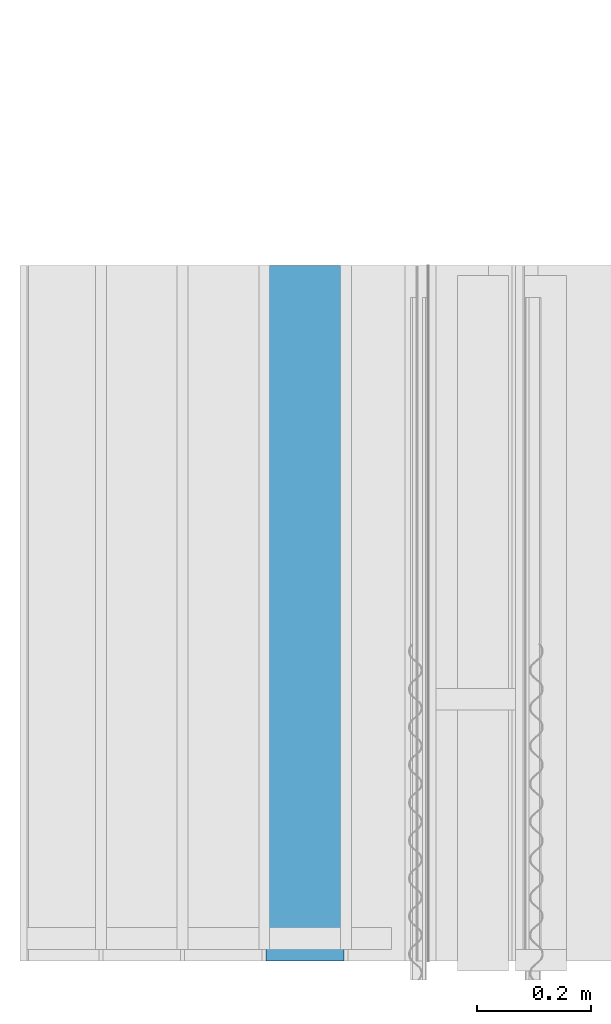
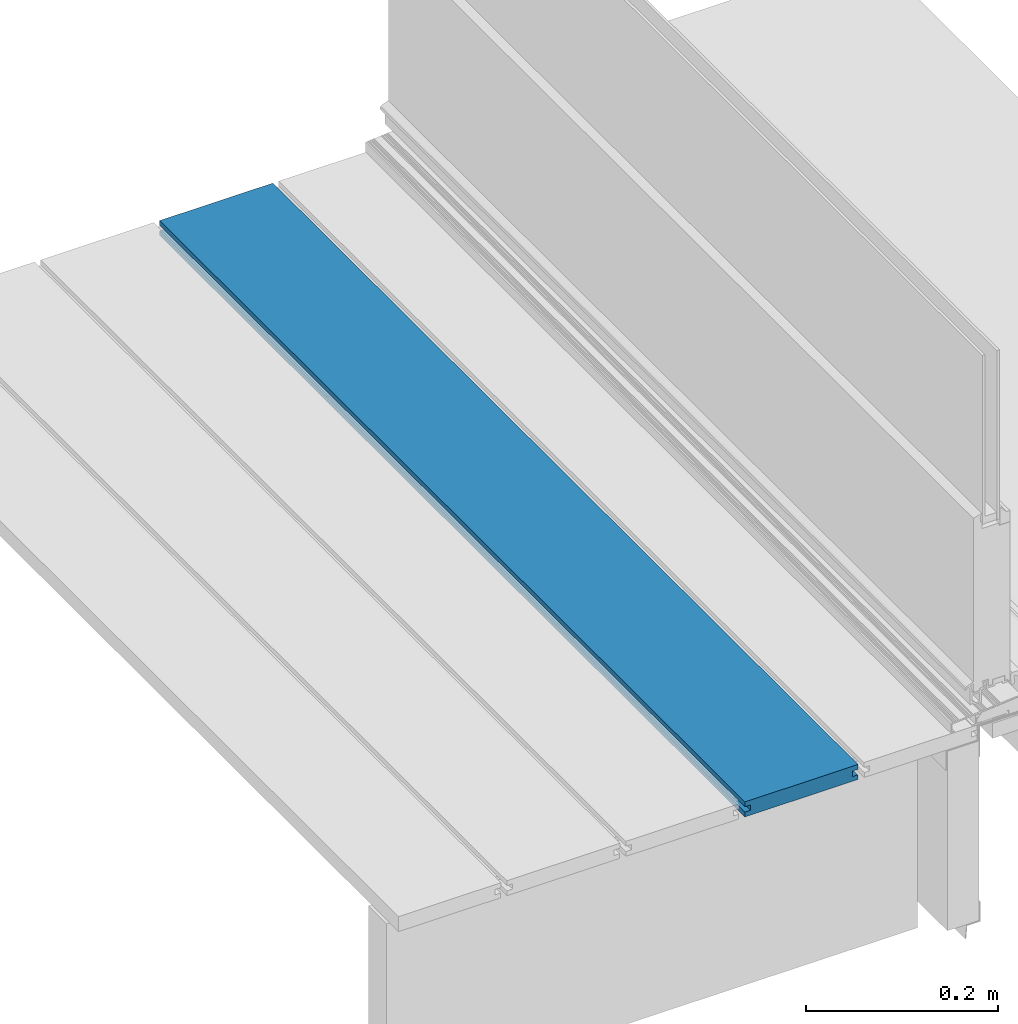
# One storey, part 5 of 33: 1 wall.
"""IFC4 building model written with IfcOpenShell, lengths in feet."""

from ifc_helpers import new_model, entity, si_unit, converted_unit, derived_unit, direction, frame, origin, place, context, subcontext, project, spatial, material, type_object, element, save


model = new_model("IFC4")

# Units and contexts
model_context = context("Model", 3, precision=0.0001, world=origin(), true_north=direction((6.12303176911189e-17, 1.0)))
body_context = subcontext(model_context, "Body", "Model", "MODEL_VIEW")
ifc_project = project(units=[converted_unit("LENGTHUNIT", "FOOT", entity("IfcRatioMeasure", 0.3048), si_unit("LENGTHUNIT", "METRE"), dimensions=[1, 0, 0, 0, 0, 0, 0]), converted_unit("AREAUNIT", "SQUARE FOOT", entity("IfcRatioMeasure", 0.09290304), si_unit("AREAUNIT", "SQUARE_METRE"), dimensions=[2, 0, 0, 0, 0, 0, 0]), converted_unit("VOLUMEUNIT", "CUBIC FOOT", entity("IfcRatioMeasure", 0.028316846592), si_unit("VOLUMEUNIT", "CUBIC_METRE"), dimensions=[3, 0, 0, 0, 0, 0, 0]), converted_unit("PLANEANGLEUNIT", "DEGREE", entity("IfcRatioMeasure", 0.0174532925199433), si_unit("PLANEANGLEUNIT", "RADIAN"), dimensions=[0, 0, 0, 0, 0, 0, 0]), si_unit("MASSUNIT", "GRAM", prefix="KILO"), derived_unit("MASSDENSITYUNIT", [(si_unit("MASSUNIT", "GRAM", prefix="KILO"), 1), (si_unit("LENGTHUNIT", "METRE"), -3)]), derived_unit("MOMENTOFINERTIAUNIT", [(si_unit("LENGTHUNIT", "METRE"), 4)]), si_unit("TIMEUNIT", "SECOND"), si_unit("FREQUENCYUNIT", "HERTZ"), si_unit("THERMODYNAMICTEMPERATUREUNIT", "DEGREE_CELSIUS"), derived_unit("THERMALTRANSMITTANCEUNIT", [(si_unit("MASSUNIT", "GRAM", prefix="KILO"), 1), (si_unit("THERMODYNAMICTEMPERATUREUNIT", "KELVIN"), -1), (si_unit("TIMEUNIT", "SECOND"), -3)]), derived_unit("VOLUMETRICFLOWRATEUNIT", [(si_unit("LENGTHUNIT", "METRE"), 3), (si_unit("TIMEUNIT", "SECOND"), -1)]), si_unit("ELECTRICCURRENTUNIT", "AMPERE"), si_unit("ELECTRICVOLTAGEUNIT", "VOLT"), si_unit("POWERUNIT", "WATT"), si_unit("FORCEUNIT", "NEWTON"), si_unit("ILLUMINANCEUNIT", "LUX"), si_unit("LUMINOUSFLUXUNIT", "LUMEN"), si_unit("LUMINOUSINTENSITYUNIT", "CANDELA"), derived_unit("USERDEFINED", [(si_unit("MASSUNIT", "GRAM", prefix="KILO"), -1), (si_unit("LENGTHUNIT", "METRE"), -2), (si_unit("TIMEUNIT", "SECOND"), 3), (si_unit("LUMINOUSFLUXUNIT", "LUMEN"), 1)]), derived_unit("LINEARVELOCITYUNIT", [(si_unit("LENGTHUNIT", "METRE"), 1), (si_unit("TIMEUNIT", "SECOND"), -1)]), si_unit("PRESSUREUNIT", "PASCAL"), derived_unit("USERDEFINED", [(si_unit("LENGTHUNIT", "METRE"), -2), (si_unit("MASSUNIT", "GRAM", prefix="KILO"), 1), (si_unit("TIMEUNIT", "SECOND"), -2)]), derived_unit("LINEARFORCEUNIT", [(si_unit("MASSUNIT", "GRAM", prefix="KILO"), 1), (si_unit("LENGTHUNIT", "METRE"), 1), (si_unit("TIMEUNIT", "SECOND"), -2), (si_unit("LENGTHUNIT", "METRE"), -1)]), derived_unit("PLANARFORCEUNIT", [(si_unit("MASSUNIT", "GRAM", prefix="KILO"), 1), (si_unit("LENGTHUNIT", "METRE"), 1), (si_unit("TIMEUNIT", "SECOND"), -2), (si_unit("LENGTHUNIT", "METRE"), -2)])], contexts=[model_context])

# Site, building, storey
site_placement = place(None, origin())
site = spatial("IfcSite", under=ifc_project, at=site_placement, CompositionType="ELEMENT")
building_placement = place(site_placement, origin())
building = spatial("IfcBuilding", under=site, at=building_placement, CompositionType="ELEMENT")
storey_placement = place(building_placement, frame((0.0, 0.0, 10.0)))
storey = spatial("IfcBuildingStorey", under=building, at=storey_placement, Name="2ND FLOOR", CompositionType="ELEMENT", Elevation=10.0000000000002)

# Wall
ifc_material = material(Name="COMPOSITE DECKING W/ HIDDEN FASTENERS", Category="Materials")
wall_type = type_object("IfcWallType", Name="Generic Models 641:Generic Models 1", PredefinedType="NOTDEFINED", material=ifc_material)
wall_placement = place(storey_placement, frame((1458.33405136118, 2.0, 0.618921366607442), z_axis=(0.0, 0.0, 1.0), x_axis=(0.0, 1.0, 0.0)))
cartesian_point_1 = entity("IfcCartesianPoint", [4.0, 0.0, 0.0])
vertex_point_1 = entity("IfcVertexPoint", cartesian_point_1)
cartesian_point_2 = entity("IfcCartesianPoint", [4.0, 0.0, 0.0198779960861497])
vertex_point_2 = entity("IfcVertexPoint", cartesian_point_2)
ifc_direction_1 = entity("IfcDirection", [0.0, 0.0, 1.0])
edge_curve_1 = entity("IfcEdgeCurve", vertex_point_1, vertex_point_2, entity("IfcTrimmedCurve", entity("IfcLine", cartesian_point_1, entity("IfcVector", ifc_direction_1, 1.0)), [cartesian_point_1], [cartesian_point_2], True, "CARTESIAN"), True)
cartesian_point_3 = entity("IfcCartesianPoint", [4.0, -0.0228400010810219, 0.0198779960861497])
vertex_point_3 = entity("IfcVertexPoint", cartesian_point_3)
ifc_direction_2 = entity("IfcDirection", [0.0, -1.0, 0.0])
edge_curve_2 = entity("IfcEdgeCurve", vertex_point_2, vertex_point_3, entity("IfcTrimmedCurve", entity("IfcLine", cartesian_point_2, entity("IfcVector", ifc_direction_2, 1.0)), [cartesian_point_2], [cartesian_point_3], True, "CARTESIAN"), True)
cartesian_point_4 = entity("IfcCartesianPoint", [4.0, -0.0228400010810219, 0.0422987663426539])
vertex_point_4 = entity("IfcVertexPoint", cartesian_point_4)
edge_curve_3 = entity("IfcEdgeCurve", vertex_point_3, vertex_point_4, entity("IfcTrimmedCurve", entity("IfcLine", cartesian_point_3, entity("IfcVector", ifc_direction_1, 1.0)), [cartesian_point_3], [cartesian_point_4], True, "CARTESIAN"), True)
cartesian_point_5 = entity("IfcCartesianPoint", [4.0, 0.0, 0.0422987663426539])
vertex_point_5 = entity("IfcVertexPoint", cartesian_point_5)
ifc_direction_3 = entity("IfcDirection", [0.0, 1.0, 0.0])
edge_curve_4 = entity("IfcEdgeCurve", vertex_point_4, vertex_point_5, entity("IfcTrimmedCurve", entity("IfcLine", cartesian_point_4, entity("IfcVector", ifc_direction_3, 1.0)), [cartesian_point_4], [cartesian_point_5], True, "CARTESIAN"), True)
cartesian_point_6 = entity("IfcCartesianPoint", [4.0, 0.0, 0.0625000000000018])
vertex_point_6 = entity("IfcVertexPoint", cartesian_point_6)
edge_curve_5 = entity("IfcEdgeCurve", vertex_point_5, vertex_point_6, entity("IfcTrimmedCurve", entity("IfcLine", cartesian_point_5, entity("IfcVector", ifc_direction_1, 1.0)), [cartesian_point_5], [cartesian_point_6], True, "CARTESIAN"), True)
cartesian_point_7 = entity("IfcCartesianPoint", [4.0, -0.446740923891639, 0.0625000000000568])
vertex_point_7 = entity("IfcVertexPoint", cartesian_point_7)
edge_curve_6 = entity("IfcEdgeCurve", vertex_point_6, vertex_point_7, entity("IfcTrimmedCurve", entity("IfcLine", cartesian_point_6, entity("IfcVector", ifc_direction_2, 1.0)), [cartesian_point_6], [cartesian_point_7], True, "CARTESIAN"), True)
cartesian_point_8 = entity("IfcCartesianPoint", [4.0, -0.446740923891639, 0.0422987663426539])
vertex_point_8 = entity("IfcVertexPoint", cartesian_point_8)
ifc_direction_4 = entity("IfcDirection", [0.0, 0.0, -1.0])
edge_curve_7 = entity("IfcEdgeCurve", vertex_point_7, vertex_point_8, entity("IfcTrimmedCurve", entity("IfcLine", cartesian_point_7, entity("IfcVector", ifc_direction_4, 1.0)), [cartesian_point_7], [cartesian_point_8], True, "CARTESIAN"), True)
cartesian_point_9 = entity("IfcCartesianPoint", [4.0, -0.423900922810844, 0.0422987663426539])
vertex_point_9 = entity("IfcVertexPoint", cartesian_point_9)
edge_curve_8 = entity("IfcEdgeCurve", vertex_point_8, vertex_point_9, entity("IfcTrimmedCurve", entity("IfcLine", cartesian_point_8, entity("IfcVector", ifc_direction_3, 1.0)), [cartesian_point_8], [cartesian_point_9], True, "CARTESIAN"), True)
cartesian_point_10 = entity("IfcCartesianPoint", [4.0, -0.423900922810844, 0.0198779960861497])
vertex_point_10 = entity("IfcVertexPoint", cartesian_point_10)
edge_curve_9 = entity("IfcEdgeCurve", vertex_point_9, vertex_point_10, entity("IfcTrimmedCurve", entity("IfcLine", cartesian_point_9, entity("IfcVector", ifc_direction_4, 1.0)), [cartesian_point_9], [cartesian_point_10], True, "CARTESIAN"), True)
cartesian_point_11 = entity("IfcCartesianPoint", [4.0, -0.445416170097133, 0.0198779960861497])
vertex_point_11 = entity("IfcVertexPoint", cartesian_point_11)
edge_curve_10 = entity("IfcEdgeCurve", vertex_point_10, vertex_point_11, entity("IfcTrimmedCurve", entity("IfcLine", cartesian_point_10, entity("IfcVector", ifc_direction_2, 1.0)), [cartesian_point_10], [cartesian_point_11], True, "CARTESIAN"), True)
cartesian_point_12 = entity("IfcCartesianPoint", [4.0, -0.445416170097133, 0.0])
vertex_point_12 = entity("IfcVertexPoint", cartesian_point_12)
edge_curve_11 = entity("IfcEdgeCurve", vertex_point_11, vertex_point_12, entity("IfcTrimmedCurve", entity("IfcLine", cartesian_point_11, entity("IfcVector", ifc_direction_4, 1.0)), [cartesian_point_11], [cartesian_point_12], True, "CARTESIAN"), True)
edge_curve_12 = entity("IfcEdgeCurve", vertex_point_12, vertex_point_1, entity("IfcTrimmedCurve", entity("IfcLine", cartesian_point_12, entity("IfcVector", ifc_direction_3, 1.0)), [cartesian_point_12], [cartesian_point_1], True, "CARTESIAN"), True)
ifc_direction_5 = entity("IfcDirection", [1.0, 0.0, 0.0])
cartesian_point_13 = entity("IfcCartesianPoint", [0.0, 0.0, 0.0])
vertex_point_13 = entity("IfcVertexPoint", cartesian_point_13)
cartesian_point_14 = entity("IfcCartesianPoint", [0.0, -0.445416170097133, 0.0])
vertex_point_14 = entity("IfcVertexPoint", cartesian_point_14)
edge_curve_13 = entity("IfcEdgeCurve", vertex_point_13, vertex_point_14, entity("IfcTrimmedCurve", entity("IfcLine", cartesian_point_13, entity("IfcVector", ifc_direction_2, 1.0)), [cartesian_point_13], [cartesian_point_14], True, "CARTESIAN"), True)
cartesian_point_15 = entity("IfcCartesianPoint", [0.0, -0.445416170097133, 0.0198779960861462])
vertex_point_15 = entity("IfcVertexPoint", cartesian_point_15)
edge_curve_14 = entity("IfcEdgeCurve", vertex_point_14, vertex_point_15, entity("IfcTrimmedCurve", entity("IfcLine", cartesian_point_14, entity("IfcVector", ifc_direction_1, 1.0)), [cartesian_point_14], [cartesian_point_15], True, "CARTESIAN"), True)
cartesian_point_16 = entity("IfcCartesianPoint", [0.0, -0.423900922810844, 0.0198779960861462])
vertex_point_16 = entity("IfcVertexPoint", cartesian_point_16)
edge_curve_15 = entity("IfcEdgeCurve", vertex_point_15, vertex_point_16, entity("IfcTrimmedCurve", entity("IfcLine", cartesian_point_15, entity("IfcVector", ifc_direction_3, 1.0)), [cartesian_point_15], [cartesian_point_16], True, "CARTESIAN"), True)
cartesian_point_17 = entity("IfcCartesianPoint", [0.0, -0.423900922810844, 0.0422987663426522])
vertex_point_17 = entity("IfcVertexPoint", cartesian_point_17)
edge_curve_16 = entity("IfcEdgeCurve", vertex_point_16, vertex_point_17, entity("IfcTrimmedCurve", entity("IfcLine", cartesian_point_16, entity("IfcVector", ifc_direction_1, 1.0)), [cartesian_point_16], [cartesian_point_17], True, "CARTESIAN"), True)
cartesian_point_18 = entity("IfcCartesianPoint", [0.0, -0.446740923891639, 0.0422987663426522])
vertex_point_18 = entity("IfcVertexPoint", cartesian_point_18)
edge_curve_17 = entity("IfcEdgeCurve", vertex_point_17, vertex_point_18, entity("IfcTrimmedCurve", entity("IfcLine", cartesian_point_17, entity("IfcVector", ifc_direction_2, 1.0)), [cartesian_point_17], [cartesian_point_18], True, "CARTESIAN"), True)
cartesian_point_19 = entity("IfcCartesianPoint", [0.0, -0.446740923891639, 0.0625000000000551])
vertex_point_19 = entity("IfcVertexPoint", cartesian_point_19)
edge_curve_18 = entity("IfcEdgeCurve", vertex_point_18, vertex_point_19, entity("IfcTrimmedCurve", entity("IfcLine", cartesian_point_18, entity("IfcVector", ifc_direction_1, 1.0)), [cartesian_point_18], [cartesian_point_19], True, "CARTESIAN"), True)
cartesian_point_20 = entity("IfcCartesianPoint", [0.0, 0.0, 0.0624999999999982])
vertex_point_20 = entity("IfcVertexPoint", cartesian_point_20)
edge_curve_19 = entity("IfcEdgeCurve", vertex_point_19, vertex_point_20, entity("IfcTrimmedCurve", entity("IfcLine", cartesian_point_19, entity("IfcVector", ifc_direction_3, 1.0)), [cartesian_point_19], [cartesian_point_20], True, "CARTESIAN"), True)
cartesian_point_21 = entity("IfcCartesianPoint", [0.0, 0.0, 0.0422987663426522])
vertex_point_21 = entity("IfcVertexPoint", cartesian_point_21)
edge_curve_20 = entity("IfcEdgeCurve", vertex_point_20, vertex_point_21, entity("IfcTrimmedCurve", entity("IfcLine", cartesian_point_20, entity("IfcVector", ifc_direction_4, 1.0)), [cartesian_point_20], [cartesian_point_21], True, "CARTESIAN"), True)
cartesian_point_22 = entity("IfcCartesianPoint", [0.0, -0.0228400010810219, 0.0422987663426522])
vertex_point_22 = entity("IfcVertexPoint", cartesian_point_22)
edge_curve_21 = entity("IfcEdgeCurve", vertex_point_21, vertex_point_22, entity("IfcTrimmedCurve", entity("IfcLine", cartesian_point_21, entity("IfcVector", ifc_direction_2, 1.0)), [cartesian_point_21], [cartesian_point_22], True, "CARTESIAN"), True)
cartesian_point_23 = entity("IfcCartesianPoint", [0.0, -0.0228400010810219, 0.0198779960861462])
vertex_point_23 = entity("IfcVertexPoint", cartesian_point_23)
edge_curve_22 = entity("IfcEdgeCurve", vertex_point_22, vertex_point_23, entity("IfcTrimmedCurve", entity("IfcLine", cartesian_point_22, entity("IfcVector", ifc_direction_4, 1.0)), [cartesian_point_22], [cartesian_point_23], True, "CARTESIAN"), True)
cartesian_point_24 = entity("IfcCartesianPoint", [0.0, 0.0, 0.0198779960861462])
vertex_point_24 = entity("IfcVertexPoint", cartesian_point_24)
edge_curve_23 = entity("IfcEdgeCurve", vertex_point_23, vertex_point_24, entity("IfcTrimmedCurve", entity("IfcLine", cartesian_point_23, entity("IfcVector", ifc_direction_3, 1.0)), [cartesian_point_23], [cartesian_point_24], True, "CARTESIAN"), True)
edge_curve_24 = entity("IfcEdgeCurve", vertex_point_24, vertex_point_13, entity("IfcTrimmedCurve", entity("IfcLine", cartesian_point_24, entity("IfcVector", ifc_direction_4, 1.0)), [cartesian_point_24], [cartesian_point_13], True, "CARTESIAN"), True)
ifc_direction_6 = entity("IfcDirection", [-1.0, 0.0, 0.0])
edge_curve_25 = entity("IfcEdgeCurve", vertex_point_24, vertex_point_2, entity("IfcTrimmedCurve", entity("IfcLine", cartesian_point_24, entity("IfcVector", ifc_direction_5, 1.0)), [cartesian_point_24], [cartesian_point_2], True, "CARTESIAN"), True)
edge_curve_26 = entity("IfcEdgeCurve", vertex_point_1, vertex_point_13, entity("IfcTrimmedCurve", entity("IfcLine", cartesian_point_13, entity("IfcVector", ifc_direction_6, 1.0)), [cartesian_point_1], [cartesian_point_13], True, "CARTESIAN"), True)
edge_curve_27 = entity("IfcEdgeCurve", vertex_point_19, vertex_point_7, entity("IfcTrimmedCurve", entity("IfcLine", cartesian_point_19, entity("IfcVector", ifc_direction_5, 1.0)), [cartesian_point_19], [cartesian_point_7], True, "CARTESIAN"), True)
edge_curve_28 = entity("IfcEdgeCurve", vertex_point_6, vertex_point_20, entity("IfcTrimmedCurve", entity("IfcLine", cartesian_point_20, entity("IfcVector", ifc_direction_6, 1.0)), [cartesian_point_6], [cartesian_point_20], True, "CARTESIAN"), True)
edge_curve_29 = entity("IfcEdgeCurve", vertex_point_18, vertex_point_8, entity("IfcTrimmedCurve", entity("IfcLine", cartesian_point_18, entity("IfcVector", ifc_direction_5, 1.0)), [cartesian_point_18], [cartesian_point_8], True, "CARTESIAN"), True)
edge_curve_30 = entity("IfcEdgeCurve", vertex_point_12, vertex_point_14, entity("IfcTrimmedCurve", entity("IfcLine", cartesian_point_14, entity("IfcVector", ifc_direction_6, 1.0)), [cartesian_point_12], [cartesian_point_14], True, "CARTESIAN"), True)
edge_curve_31 = entity("IfcEdgeCurve", vertex_point_5, vertex_point_21, entity("IfcTrimmedCurve", entity("IfcLine", cartesian_point_21, entity("IfcVector", ifc_direction_6, 1.0)), [cartesian_point_5], [cartesian_point_21], True, "CARTESIAN"), True)
edge_curve_32 = entity("IfcEdgeCurve", vertex_point_17, vertex_point_9, entity("IfcTrimmedCurve", entity("IfcLine", cartesian_point_17, entity("IfcVector", ifc_direction_5, 1.0)), [cartesian_point_17], [cartesian_point_9], True, "CARTESIAN"), True)
edge_curve_33 = entity("IfcEdgeCurve", vertex_point_16, vertex_point_10, entity("IfcTrimmedCurve", entity("IfcLine", cartesian_point_16, entity("IfcVector", ifc_direction_5, 1.0)), [cartesian_point_16], [cartesian_point_10], True, "CARTESIAN"), True)
edge_curve_34 = entity("IfcEdgeCurve", vertex_point_15, vertex_point_11, entity("IfcTrimmedCurve", entity("IfcLine", cartesian_point_15, entity("IfcVector", ifc_direction_5, 1.0)), [cartesian_point_15], [cartesian_point_11], True, "CARTESIAN"), True)
edge_curve_35 = entity("IfcEdgeCurve", vertex_point_23, vertex_point_3, entity("IfcTrimmedCurve", entity("IfcLine", cartesian_point_23, entity("IfcVector", ifc_direction_5, 1.0)), [cartesian_point_23], [cartesian_point_3], True, "CARTESIAN"), True)
edge_curve_36 = entity("IfcEdgeCurve", vertex_point_22, vertex_point_4, entity("IfcTrimmedCurve", entity("IfcLine", cartesian_point_22, entity("IfcVector", ifc_direction_5, 1.0)), [cartesian_point_22], [cartesian_point_4], True, "CARTESIAN"), True)
element("IfcWall", 1, at=wall_placement, inside=storey, type_object=wall_type, material=ifc_material, Name="Generic Models 641:Generic Models 1", ObjectType="Generic Models 641:Generic Models 1", PredefinedType="NOTDEFINED", context=body_context, shape_type="AdvancedBrep", body=[
    entity("IfcAdvancedBrep", entity("IfcClosedShell", [entity("IfcAdvancedFace", [entity("IfcFaceOuterBound", entity("IfcEdgeLoop", [entity("IfcOrientedEdge", None, None, edge_curve_1, True), entity("IfcOrientedEdge", None, None, edge_curve_2, True), entity("IfcOrientedEdge", None, None, edge_curve_3, True), entity("IfcOrientedEdge", None, None, edge_curve_4, True), entity("IfcOrientedEdge", None, None, edge_curve_5, True), entity("IfcOrientedEdge", None, None, edge_curve_6, True), entity("IfcOrientedEdge", None, None, edge_curve_7, True), entity("IfcOrientedEdge", None, None, edge_curve_8, True), entity("IfcOrientedEdge", None, None, edge_curve_9, True), entity("IfcOrientedEdge", None, None, edge_curve_10, True), entity("IfcOrientedEdge", None, None, edge_curve_11, True), entity("IfcOrientedEdge", None, None, edge_curve_12, True)]), True)], entity("IfcPlane", entity("IfcAxis2Placement3D", entity("IfcCartesianPoint", [4.0, 3.98642313864389, 0.0]), ifc_direction_5, ifc_direction_3)), True), entity("IfcAdvancedFace", [entity("IfcFaceOuterBound", entity("IfcEdgeLoop", [entity("IfcOrientedEdge", None, None, edge_curve_13, True), entity("IfcOrientedEdge", None, None, edge_curve_14, True), entity("IfcOrientedEdge", None, None, edge_curve_15, True), entity("IfcOrientedEdge", None, None, edge_curve_16, True), entity("IfcOrientedEdge", None, None, edge_curve_17, True), entity("IfcOrientedEdge", None, None, edge_curve_18, True), entity("IfcOrientedEdge", None, None, edge_curve_19, True), entity("IfcOrientedEdge", None, None, edge_curve_20, True), entity("IfcOrientedEdge", None, None, edge_curve_21, True), entity("IfcOrientedEdge", None, None, edge_curve_22, True), entity("IfcOrientedEdge", None, None, edge_curve_23, True), entity("IfcOrientedEdge", None, None, edge_curve_24, True)]), True)], entity("IfcPlane", entity("IfcAxis2Placement3D", entity("IfcCartesianPoint", [0.0, 3.98642313864389, 0.0]), ifc_direction_6, ifc_direction_2)), True), entity("IfcAdvancedFace", [entity("IfcFaceOuterBound", entity("IfcEdgeLoop", [entity("IfcOrientedEdge", None, None, edge_curve_24, False), entity("IfcOrientedEdge", None, None, edge_curve_25, True), entity("IfcOrientedEdge", None, None, edge_curve_1, False), entity("IfcOrientedEdge", None, None, edge_curve_26, True)]), True)], entity("IfcPlane", entity("IfcAxis2Placement3D", cartesian_point_24, ifc_direction_3, ifc_direction_5)), True), entity("IfcAdvancedFace", [entity("IfcFaceOuterBound", entity("IfcEdgeLoop", [entity("IfcOrientedEdge", None, None, edge_curve_19, False), entity("IfcOrientedEdge", None, None, edge_curve_27, True), entity("IfcOrientedEdge", None, None, edge_curve_6, False), entity("IfcOrientedEdge", None, None, edge_curve_28, True)]), True)], entity("IfcPlane", entity("IfcAxis2Placement3D", cartesian_point_19, ifc_direction_1, ifc_direction_5)), True), entity("IfcAdvancedFace", [entity("IfcFaceOuterBound", entity("IfcEdgeLoop", [entity("IfcOrientedEdge", None, None, edge_curve_18, False), entity("IfcOrientedEdge", None, None, edge_curve_29, True), entity("IfcOrientedEdge", None, None, edge_curve_7, False), entity("IfcOrientedEdge", None, None, edge_curve_27, False)]), True)], entity("IfcPlane", entity("IfcAxis2Placement3D", cartesian_point_18, ifc_direction_2, ifc_direction_5)), True), entity("IfcAdvancedFace", [entity("IfcFaceOuterBound", entity("IfcEdgeLoop", [entity("IfcOrientedEdge", None, None, edge_curve_13, False), entity("IfcOrientedEdge", None, None, edge_curve_26, False), entity("IfcOrientedEdge", None, None, edge_curve_12, False), entity("IfcOrientedEdge", None, None, edge_curve_30, True)]), True)], entity("IfcPlane", entity("IfcAxis2Placement3D", cartesian_point_13, ifc_direction_4, ifc_direction_5)), True), entity("IfcAdvancedFace", [entity("IfcFaceOuterBound", entity("IfcEdgeLoop", [entity("IfcOrientedEdge", None, None, edge_curve_20, False), entity("IfcOrientedEdge", None, None, edge_curve_28, False), entity("IfcOrientedEdge", None, None, edge_curve_5, False), entity("IfcOrientedEdge", None, None, edge_curve_31, True)]), True)], entity("IfcPlane", entity("IfcAxis2Placement3D", cartesian_point_20, ifc_direction_3, ifc_direction_5)), True), entity("IfcAdvancedFace", [entity("IfcFaceOuterBound", entity("IfcEdgeLoop", [entity("IfcOrientedEdge", None, None, edge_curve_17, False), entity("IfcOrientedEdge", None, None, edge_curve_32, True), entity("IfcOrientedEdge", None, None, edge_curve_8, False), entity("IfcOrientedEdge", None, None, edge_curve_29, False)]), True)], entity("IfcPlane", entity("IfcAxis2Placement3D", cartesian_point_17, ifc_direction_4, ifc_direction_5)), True), entity("IfcAdvancedFace", [entity("IfcFaceOuterBound", entity("IfcEdgeLoop", [entity("IfcOrientedEdge", None, None, edge_curve_16, False), entity("IfcOrientedEdge", None, None, edge_curve_33, True), entity("IfcOrientedEdge", None, None, edge_curve_9, False), entity("IfcOrientedEdge", None, None, edge_curve_32, False)]), True)], entity("IfcPlane", entity("IfcAxis2Placement3D", cartesian_point_16, ifc_direction_2, ifc_direction_5)), True), entity("IfcAdvancedFace", [entity("IfcFaceOuterBound", entity("IfcEdgeLoop", [entity("IfcOrientedEdge", None, None, edge_curve_15, False), entity("IfcOrientedEdge", None, None, edge_curve_34, True), entity("IfcOrientedEdge", None, None, edge_curve_10, False), entity("IfcOrientedEdge", None, None, edge_curve_33, False)]), True)], entity("IfcPlane", entity("IfcAxis2Placement3D", cartesian_point_15, ifc_direction_1, ifc_direction_5)), True), entity("IfcAdvancedFace", [entity("IfcFaceOuterBound", entity("IfcEdgeLoop", [entity("IfcOrientedEdge", None, None, edge_curve_14, False), entity("IfcOrientedEdge", None, None, edge_curve_30, False), entity("IfcOrientedEdge", None, None, edge_curve_11, False), entity("IfcOrientedEdge", None, None, edge_curve_34, False)]), True)], entity("IfcPlane", entity("IfcAxis2Placement3D", cartesian_point_14, ifc_direction_2, ifc_direction_5)), True), entity("IfcAdvancedFace", [entity("IfcFaceOuterBound", entity("IfcEdgeLoop", [entity("IfcOrientedEdge", None, None, edge_curve_23, False), entity("IfcOrientedEdge", None, None, edge_curve_35, True), entity("IfcOrientedEdge", None, None, edge_curve_2, False), entity("IfcOrientedEdge", None, None, edge_curve_25, False)]), True)], entity("IfcPlane", entity("IfcAxis2Placement3D", cartesian_point_23, ifc_direction_1, ifc_direction_5)), True), entity("IfcAdvancedFace", [entity("IfcFaceOuterBound", entity("IfcEdgeLoop", [entity("IfcOrientedEdge", None, None, edge_curve_22, False), entity("IfcOrientedEdge", None, None, edge_curve_36, True), entity("IfcOrientedEdge", None, None, edge_curve_3, False), entity("IfcOrientedEdge", None, None, edge_curve_35, False)]), True)], entity("IfcPlane", entity("IfcAxis2Placement3D", cartesian_point_22, ifc_direction_3, ifc_direction_5)), True), entity("IfcAdvancedFace", [entity("IfcFaceOuterBound", entity("IfcEdgeLoop", [entity("IfcOrientedEdge", None, None, edge_curve_21, False), entity("IfcOrientedEdge", None, None, edge_curve_31, False), entity("IfcOrientedEdge", None, None, edge_curve_4, False), entity("IfcOrientedEdge", None, None, edge_curve_36, False)]), True)], entity("IfcPlane", entity("IfcAxis2Placement3D", cartesian_point_21, ifc_direction_4, ifc_direction_5)), True)])),
])

save(model, "model.ifc")
